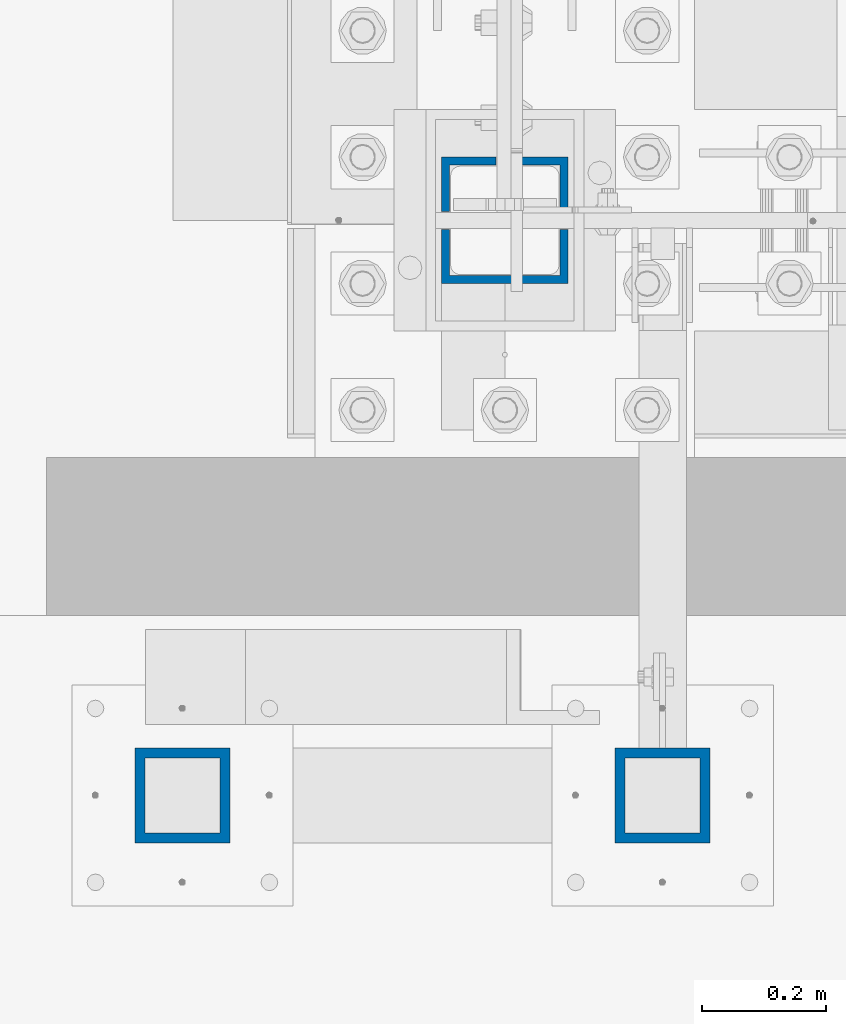
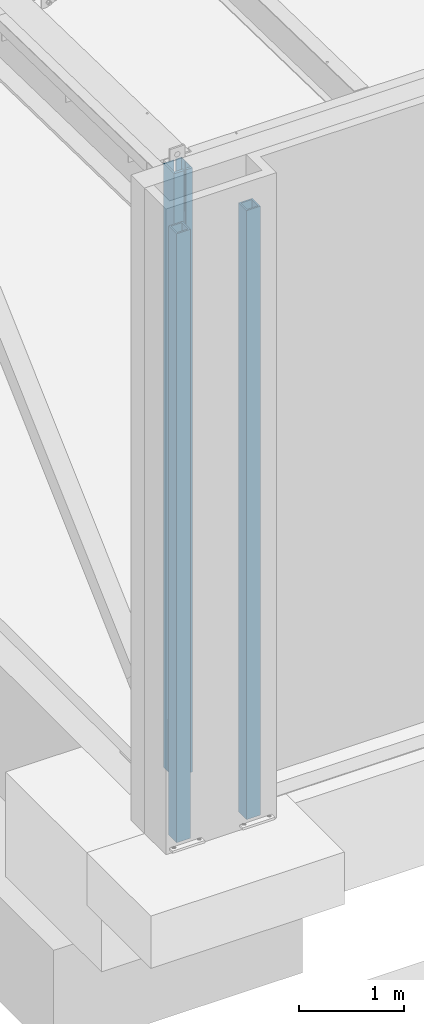
# One storey, part 873 of 1763: 3 columns, 2 elements without a shape of their own.
"""IFC2X3 building model written with IfcOpenShell, lengths in millimetres."""

from ifc_helpers import new_model, si_unit, frame, origin_with_axes, place, context, subcontext, project, spatial, faceted_brep, material, type_object, element, aggregate, save


model = new_model("IFC2X3")

# Units and contexts
model_context = context("Model", 3, precision=1e-05, world=origin_with_axes())
body_context = subcontext(model_context, "Body", "Model", "MODEL_VIEW")
ifc_project = project(units=[si_unit("LENGTHUNIT", "METRE", prefix="MILLI"), si_unit("AREAUNIT", "SQUARE_METRE"), si_unit("VOLUMEUNIT", "CUBIC_METRE"), si_unit("MASSUNIT", "GRAM", prefix="KILO"), si_unit("TIMEUNIT", "SECOND"), si_unit("PLANEANGLEUNIT", "RADIAN"), si_unit("SOLIDANGLEUNIT", "STERADIAN"), si_unit("THERMODYNAMICTEMPERATUREUNIT", "DEGREE_CELSIUS"), si_unit("LUMINOUSINTENSITYUNIT", "LUMEN")], contexts=[model_context])

# Site, building, storey
site_placement = place(None, origin_with_axes())
site = spatial("IfcSite", under=ifc_project, at=site_placement, CompositionType="ELEMENT")
building_placement = place(site_placement, origin_with_axes())
building = spatial("IfcBuilding", under=site, at=building_placement, Name="Undefined", CompositionType="ELEMENT")
storey_placement = place(building_placement, origin_with_axes())
storey = spatial("IfcBuildingStorey", under=building, at=storey_placement, Name="Undefined", CompositionType="ELEMENT", Elevation=0.0)

# Assembly, columns
assembly_1_placement = place(storey_placement, origin_with_axes())
assembly_1 = element("IfcElementAssembly", 1, at=assembly_1_placement, inside=storey, Name="FRAME", AssemblyPlace="NOTDEFINED", PredefinedType="RIGID_FRAME")
ifc_material = material()
column_type_1 = type_object("IfcColumnType", Name="HSS6X6X5/8", PredefinedType="NOTDEFINED")
column_1_placement = place(assembly_1_placement, frame((-87121.9811228712, -14639.925, 5029.2), z_axis=(0.0, 1.0, 0.0), x_axis=(0.0, 0.0, 1.0)))
column_1 = element("IfcColumn", 2, at=column_1_placement, type_object=column_type_1, material=ifc_material, Name="COLUMN", ObjectType="HSS6X6X5/8", context=body_context, shape_type="Brep", body=[
    faceted_brep([(63.4999999999973, 60.3249999999971, -60.3250000000007), (63.4999999999973, -60.3249999999971, -60.3250000000007), (7156.45, -60.3249999999971, -60.3250000000007), (7156.45, 60.3249999999971, -60.3250000000007), (63.4999999999973, -60.3249999999971, 60.3250000000007), (7156.45, -60.3249999999971, 60.3250000000007), (63.4999999999973, 60.3249999999971, 60.3250000000007), (7156.45, 60.3249999999971, 60.3250000000007), (63.4999999999973, 76.1999999999971, -76.2000000000007), (63.4999999999973, 76.1999999999971, 76.2000000000007), (7156.45, 76.1999999999971, 76.2000000000007), (7156.45, 76.1999999999971, -76.2000000000007), (63.4999999999973, -76.1999999999971, 76.2000000000007), (7156.45, -76.1999999999971, 76.2000000000007), (63.4999999999973, -76.1999999999971, -76.2000000000007), (7156.45, -76.1999999999971, -76.2000000000007)], [[[0, 1, 2, 3]], [[1, 4, 5, 2]], [[4, 6, 7, 5]], [[6, 0, 3, 7]], [[8, 9, 10, 11]], [[9, 12, 13, 10]], [[12, 14, 15, 13]], [[14, 8, 11, 15]], [[13, 15, 11, 10], [5, 7, 3, 2]], [[14, 12, 9, 8], [6, 4, 1, 0]]]),
])
column_2_placement = place(assembly_1_placement, frame((-87893.5063181838, -14639.925, 5029.2), z_axis=(0.0, 1.0, 0.0), x_axis=(0.0, 0.0, 1.0)))
column_2 = element("IfcColumn", 3, at=column_2_placement, type_object=column_type_1, material=ifc_material, Name="FRAME", ObjectType="HSS6X6X5/8", context=body_context, shape_type="Brep", body=[
    faceted_brep([(63.4999999999973, 60.3249999999971, -60.3250000000007), (63.4999999999973, -60.3249999999971, -60.3250000000007), (7156.45, -60.3249999999971, -60.3250000000007), (7156.45, 60.3249999999971, -60.3250000000007), (63.4999999999973, -60.3249999999971, 60.3250000000007), (7156.45, -60.3249999999971, 60.3250000000007), (63.4999999999973, 60.3249999999971, 60.3250000000007), (7156.45, 60.3249999999971, 60.3250000000007), (63.4999999999973, 76.1999999999971, -76.2000000000007), (63.4999999999973, 76.1999999999971, 76.2000000000007), (7156.45, 76.1999999999971, 76.2000000000007), (7156.45, 76.1999999999971, -76.2000000000007), (63.4999999999973, -76.1999999999971, 76.2000000000007), (7156.45, -76.1999999999971, 76.2000000000007), (63.4999999999973, -76.1999999999971, -76.2000000000007), (7156.45, -76.1999999999971, -76.2000000000007)], [[[0, 1, 2, 3]], [[1, 4, 5, 2]], [[4, 6, 7, 5]], [[6, 0, 3, 7]], [[8, 9, 10, 11]], [[9, 12, 13, 10]], [[12, 14, 15, 13]], [[14, 8, 11, 15]], [[13, 15, 11, 10], [5, 7, 3, 2]], [[14, 12, 9, 8], [6, 4, 1, 0]]]),
])
aggregate(assembly_1, [column_1, column_2])

# Assembly, column
assembly_2_placement = place(storey_placement, origin_with_axes())
assembly_2 = element("IfcElementAssembly", 4, at=assembly_2_placement, inside=storey, Name="COLUMN", AssemblyPlace="NOTDEFINED", PredefinedType="RIGID_FRAME")
column_type_2 = type_object("IfcColumnType", Name="HSS8X8X1/2", PredefinedType="NOTDEFINED")
column_3_placement = place(assembly_2_placement, frame((-87375.4372736983, -13716.0, 5029.2), z_axis=(0.0, 1.0, 0.0), x_axis=(0.0, 0.0, 1.0)))
column_3 = element("IfcColumn", 5, at=column_3_placement, type_object=column_type_2, material=ifc_material, Name="COLUMN", ObjectType="HSS8X8X1/2", context=body_context, shape_type="Brep", body=[
    faceted_brep([(7150.10000000001, -88.9000000000015, -88.8999999999996), (7137.40000000001, -101.599999999999, -101.6), (7137.4, 7.93749961852154, -101.6), (7150.1, 7.93749961852154, -88.8999999999996), (7150.10000000001, -88.9000000000015, 88.8999999999996), (7137.40000000001, -101.599999999999, 101.6), (7150.10000000001, 88.9000000000015, 88.8999999999996), (7150.1, 88.8999999999942, 23.0189311922004), (7137.4, 101.600000000006, 23.0189311922004), (7137.40000000001, 101.599999999999, 101.6), (7150.1, 30.1624999999913, -88.8999999999996), (7137.4, 30.1624999999913, -101.6), (7137.40000000001, 101.599999999999, -101.6), (7150.10000000001, 88.9000000000015, -88.8999999999996), (7137.40000000001, 101.600000000006, 10.3189310014568), (7150.10000000001, 88.8999999999942, 10.3189310014568), (6565.9000243187, 88.8999999999942, 23.0189311922004), (6565.9000243187, 101.600000000006, 23.0189311922004), (6563.46998455967, 88.8999999999942, 22.5355662309066), (6563.46998455967, 101.600000000006, 22.5355662309066), (6561.4098963256, 88.8999999999942, 21.1590592806679), (6561.4098963256, 101.600000000006, 21.1590592806679), (6560.03338937536, 88.8999999999942, 19.098971046591), (6560.03338937536, 101.600000000006, 19.098971046591), (6559.55002441406, 88.8999999999942, 16.6689312875678), (6559.55002441406, 101.600000000006, 16.6689312875678), (6560.03338937536, 88.8999999999942, 14.2388915285446), (6560.03338937536, 101.600000000006, 14.2388915285446), (6561.4098963256, 88.8999999999942, 12.1788032944678), (6561.4098963256, 101.600000000006, 12.1788032944678), (6563.46998455967, 88.8999999999942, 10.802296344229), (6563.46998455967, 101.600000000006, 10.802296344229), (6565.9000243187, 88.8999999999942, 10.3189313829353), (6565.9000243187, 101.600000000006, 10.3189313829353), (6476.19795442605, 7.93749961852154, 88.8999999999996), (6476.19795442605, 7.93749961852154, 101.6), (7137.4, 7.93749961852154, 101.6), (7150.1, 7.93749961852154, 88.8999999999996), (6471.9453847109, 8.78338832801091, 88.8999999999996), (6471.9453847109, 8.78338832801091, 101.6), (6468.34023018524, 11.19227556845, 88.8999999999996), (6468.34023018524, 11.19227556845, 101.6), (6465.9313429448, 14.7974300941132, 88.8999999999996), (6465.9313429448, 14.7974300941132, 101.6), (6465.08545423531, 19.0499998092564, 88.8999999999996), (6465.08545423531, 19.0499998092564, 101.6), (6465.9313429448, 23.3025695243996, 88.8999999999996), (6465.9313429448, 23.3025695243996, 101.6), (6468.34023018524, 26.9077240500628, 88.8999999999996), (6468.34023018524, 26.9077240500628, 101.6), (6471.9453847109, 29.3166112905019, 88.8999999999996), (6471.9453847109, 29.3166112905019, 101.6), (6476.19795442605, 30.1624999999913, 88.8999999999996), (6476.19795442605, 30.1624999999913, 101.6), (7150.1, 30.1624999999913, 88.8999999999996), (7137.4, 30.1624999999913, 101.6), (101.599999999999, 101.599999999999, 101.6), (101.600000000009, 14.2875007629336, 101.6), (678.599895004965, 14.2875007629336, 101.6), (683.459974523011, 13.3207708403497, 101.6), (687.580150991164, 10.5677569398686, 101.6), (690.333164891643, 6.44758047170762, 101.6), (691.29989481423, 1.5875009536685, 101.6), (691.29989481423, -1.58750019074068, 101.6), (690.333164891643, -6.44757970877981, 101.6), (687.580150991164, -10.5677561769407, 101.6), (683.459974523011, -13.3207700774219, 101.6), (678.599895004965, -14.2875000000058, 101.6), (101.600000000009, -14.2875000000058, 101.6), (101.599999999999, -101.599999999999, 101.6), (101.599999999999, 101.599999999999, -101.6), (101.599999999999, 101.599999999999, -14.2875000000004), (713.240502002579, 101.600000000006, -14.287500000004), (718.100581520624, 101.600000000006, -13.3207700774165), (722.220757988778, 101.600000000006, -10.5677561769389), (724.973771889257, 101.600000000006, -6.44757970878527), (725.940501811844, 101.600000000006, -1.58750019073887), (725.940501811844, 101.600000000006, 1.58750095367031), (724.973771889257, 101.600000000006, 6.44758047171672), (722.220757988778, 101.600000000006, 10.5677569398704), (718.100581520624, 101.600000000006, 13.3207708403479), (713.240502002579, 101.600000000006, 14.2875007629355), (101.599999999999, 101.599999999999, 14.2875007629391), (6476.19796663308, 7.93749961852154, -88.8999999999996), (6476.19796663308, 7.93749961852154, -101.6), (6471.94539691793, 8.78338832801091, -101.6), (6471.94539691793, 8.78338832801091, -88.8999999999996), (6468.34024239228, 11.19227556845, -101.6), (6468.34024239228, 11.19227556845, -88.8999999999996), (6465.93135515183, 14.7974300941132, -101.6), (6465.93135515183, 14.7974300941132, -88.8999999999996), (6465.08546644235, 19.0499998092564, -101.6), (6465.08546644235, 19.0499998092564, -88.8999999999996), (6465.93135515183, 23.3025695243996, -101.6), (6465.93135515183, 23.3025695243996, -88.8999999999996), (6468.34024239228, 26.9077240500628, -101.6), (6468.34024239228, 26.9077240500628, -88.8999999999996), (6471.94539691793, 29.3166112905019, -101.6), (6471.94539691793, 29.3166112905019, -88.8999999999996), (6476.19796663308, 30.1624999999913, -101.6), (6476.19796663308, 30.1624999999913, -88.8999999999996), (101.599999999999, 88.9000000000015, -88.8999999999996), (101.599999999999, -88.9000000000015, -88.8999999999996), (101.599999999999, -101.599999999999, -101.6), (101.599999999999, -101.599999999999, 14.2875007629391), (713.240502002579, -101.600000000006, 14.2875007629355), (718.100581520624, -101.600000000006, 13.3207708403479), (722.220757988778, -101.600000000006, 10.5677569398704), (724.973771889257, -101.600000000006, 6.44758047171672), (725.940501811844, -101.600000000006, 1.58750095367031), (725.940501811844, -101.600000000006, -1.58750019073887), (724.973771889257, -101.600000000006, -6.44757970878527), (722.220757988778, -101.600000000006, -10.5677561769389), (718.100581520624, -101.600000000006, -13.3207700774165), (713.240502002579, -101.600000000006, -14.287500000004), (101.599999999999, -101.599999999999, -14.2875000000004), (101.599999999999, -88.9000000000015, 14.2875007629391), (713.240502002579, -88.8999999999942, 14.2875007629355), (718.100581520624, -88.8999999999942, 13.3207708403479), (722.220757988778, -88.8999999999942, 10.5677569398704), (724.973771889257, -88.8999999999942, 6.44758047171672), (725.940501811844, -88.8999999999942, 1.58750095367031), (725.940501811844, -88.8999999999942, -1.58750019073887), (724.973771889257, -88.8999999999942, -6.44757970878527), (722.220757988778, -88.8999999999942, -10.5677561769389), (718.100581520624, -88.8999999999942, -13.3207700774165), (713.240502002579, -88.8999999999942, -14.287500000004), (101.599999999999, -88.9000000000015, -14.2875000000004), (101.599999999999, 88.9000000000015, -14.2875000000004), (713.240502002579, 88.8999999999942, -14.287500000004), (718.100581520624, 88.8999999999942, -13.3207700774165), (722.220757988778, 88.8999999999942, -10.5677561769389), (724.973771889257, 88.8999999999942, -6.44757970878527), (725.940501811844, 88.8999999999942, -1.58750019073887), (725.940501811844, 88.8999999999942, 1.58750095367031), (724.973771889257, 88.8999999999942, 6.44758047171672), (722.220757988778, 88.8999999999942, 10.5677569398704), (718.100581520624, 88.8999999999942, 13.3207708403479), (713.240502002579, 88.8999999999942, 14.2875007629355), (101.599999999999, 88.9000000000015, 14.2875007629391), (101.599999999999, 88.9000000000015, 88.8999999999996), (101.600000000009, 14.2875007629336, 88.8999999999996), (678.599895004965, 14.2875007629336, 88.8999999999996), (683.459974523011, 13.3207708403497, 88.8999999999996), (687.580150991164, 10.5677569398686, 88.8999999999996), (690.333164891643, 6.44758047170762, 88.8999999999996), (691.29989481423, 1.5875009536685, 88.8999999999996), (691.29989481423, -1.58750019074068, 88.8999999999996), (690.333164891643, -6.44757970877981, 88.8999999999996), (687.580150991164, -10.5677561769407, 88.8999999999996), (683.459974523011, -13.3207700774219, 88.8999999999996), (678.599895004965, -14.2875000000058, 88.8999999999996), (101.600000000009, -14.2875000000058, 88.8999999999996), (101.599999999999, -88.9000000000015, 88.8999999999996)], [[[0, 1, 2, 3]], [[4, 5, 1, 0]], [[6, 7, 8, 9]], [[10, 11, 12, 13]], [[13, 12, 14, 15]], [[16, 17, 8, 7]], [[18, 19, 17, 16]], [[20, 21, 19, 18]], [[22, 23, 21, 20]], [[24, 25, 23, 22]], [[26, 27, 25, 24]], [[28, 29, 27, 26]], [[30, 31, 29, 28]], [[32, 33, 31, 30]], [[33, 32, 15, 14]], [[34, 35, 36, 37]], [[35, 34, 38, 39]], [[39, 38, 40, 41]], [[41, 40, 42, 43]], [[43, 42, 44, 45]], [[45, 44, 46, 47]], [[47, 46, 48, 49]], [[49, 48, 50, 51]], [[51, 50, 52, 53]], [[53, 52, 54, 55]], [[35, 39, 41, 43, 45, 47, 49, 51, 53, 55, 9, 56, 57, 58, 59, 60, 61, 62, 63, 64, 65, 66, 67, 68, 69, 5, 36]], [[17, 19, 21, 23, 25, 27, 29, 31, 33, 14, 12, 70, 71, 72, 73, 74, 75, 76, 77, 78, 79, 80, 81, 82, 56, 9, 8]], [[83, 84, 85, 86]], [[86, 85, 87, 88]], [[88, 87, 89, 90]], [[90, 89, 91, 92]], [[92, 91, 93, 94]], [[94, 93, 95, 96]], [[96, 95, 97, 98]], [[98, 97, 99, 100]], [[100, 99, 11, 10]], [[83, 86, 88, 90, 92, 94, 96, 98, 100, 10, 13, 101, 102, 0, 3]], [[84, 83, 3, 2]], [[103, 70, 12, 11, 99, 97, 95, 93, 91, 89, 87, 85, 84, 2, 1]], [[69, 104, 105, 106, 107, 108, 109, 110, 111, 112, 113, 114, 115, 103, 1, 5]], [[104, 116, 117, 105]], [[105, 117, 118, 106]], [[106, 118, 119, 107]], [[107, 119, 120, 108]], [[108, 120, 121, 109]], [[109, 121, 122, 110]], [[110, 122, 123, 111]], [[111, 123, 124, 112]], [[112, 124, 125, 113]], [[113, 125, 126, 114]], [[114, 126, 127, 115]], [[102, 101, 128, 71, 70, 103, 115, 127]], [[129, 72, 71, 128]], [[130, 73, 72, 129]], [[131, 74, 73, 130]], [[132, 75, 74, 131]], [[133, 76, 75, 132]], [[134, 77, 76, 133]], [[135, 78, 77, 134]], [[136, 79, 78, 135]], [[137, 80, 79, 136]], [[138, 81, 80, 137]], [[139, 82, 81, 138]], [[56, 82, 139, 140, 141, 57]], [[57, 141, 142, 58]], [[58, 142, 143, 59]], [[59, 143, 144, 60]], [[60, 144, 145, 61]], [[61, 145, 146, 62]], [[62, 146, 147, 63]], [[63, 147, 148, 64]], [[64, 148, 149, 65]], [[65, 149, 150, 66]], [[66, 150, 151, 67]], [[67, 151, 152, 68]], [[153, 116, 104, 69, 68, 152]], [[102, 127, 126, 125, 124, 123, 122, 121, 120, 119, 118, 117, 116, 153, 4, 0]], [[37, 36, 5, 4]], [[153, 152, 151, 150, 149, 148, 147, 146, 145, 144, 143, 142, 141, 140, 6, 54, 52, 50, 48, 46, 44, 42, 40, 38, 34, 37, 4]], [[55, 54, 6, 9]], [[140, 139, 138, 137, 136, 135, 134, 133, 132, 131, 130, 129, 128, 101, 13, 15, 32, 30, 28, 26, 24, 22, 20, 18, 16, 7, 6]]]),
])
aggregate(assembly_2, [column_3])

save(model, "model.ifc")
